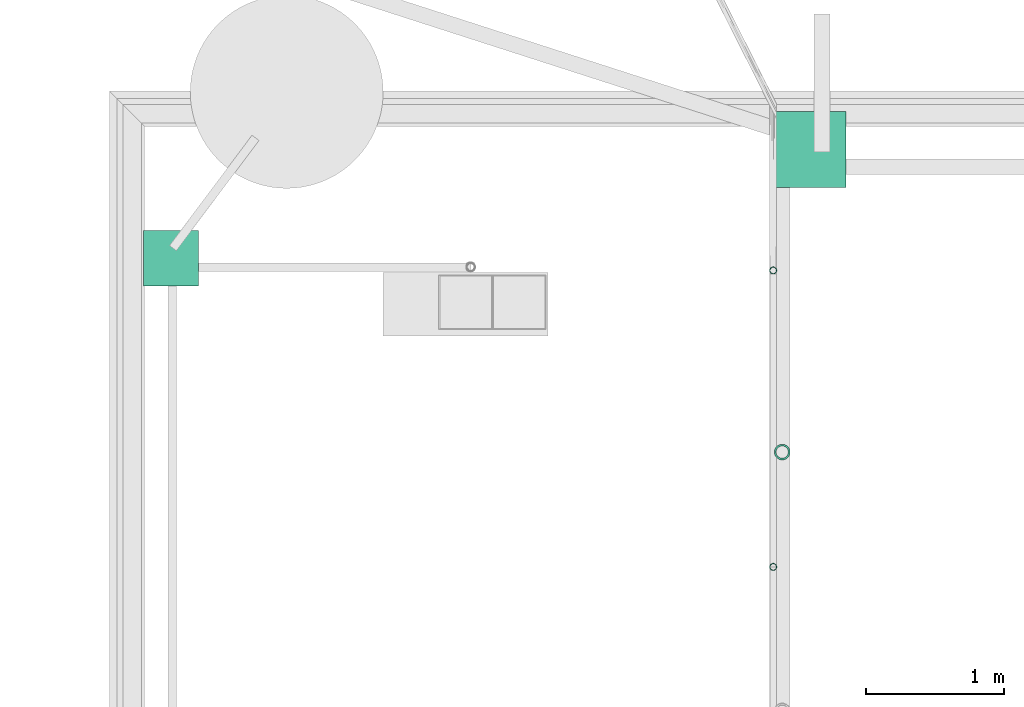
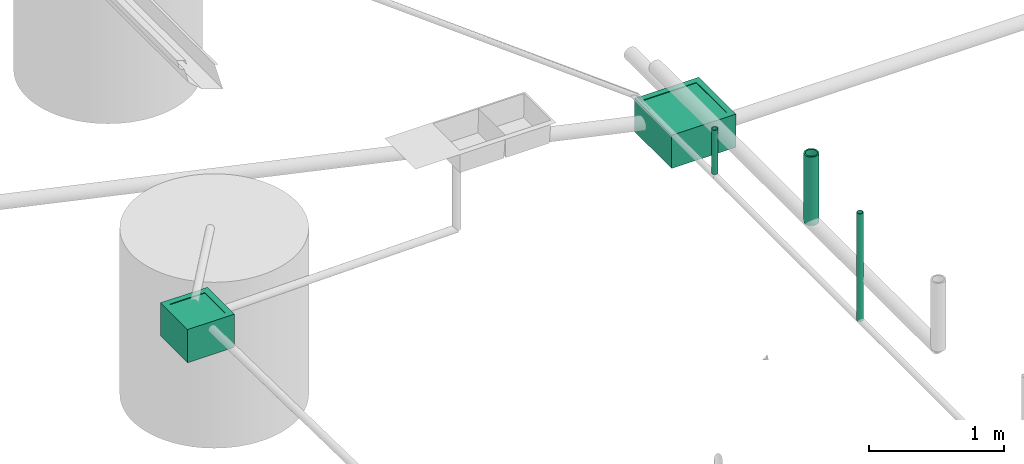
# One storey, part 11 of 15: 3 pipe segments, 2 distribution chamber elements.
"""IFC4X3_ADD2 building model written with IfcOpenShell, lengths in metres."""

import ifcopenshell
import ifcopenshell.guid

model = None  # the IFC model being written
_history = None  # IfcOwnerHistory: only IFC2X3 demands one
_inside = {}  # id of a spatial element -> (the spatial element, [elements in it])
_under = {}  # id of a project, library or spatial element -> (it, [spatial elements below it])
_declared = {}  # id of a project -> (the project, [libraries it declares])
_typed = {}  # id of a type object -> (the type object, [elements of that type])
_made_of = {}  # id of a material, layer set ... -> (it, [elements and type objects made of it])


def new_model(schema):
    """Start an empty IFC model of exactly this schema.

    Asked for "IFC4X3", IfcOpenShell would pick the latest addendum, in which some entities
    have other attributes; the version numbers below select the first issue.
    IFC2X3 requires an IfcOwnerHistory on every rooted entity: one is made here for all.
    """
    global model, _history
    if schema == "IFC4X3":
        model = ifcopenshell.file(schema_version=(4, 3, 0, 0))
    else:
        model = ifcopenshell.file(schema=schema)
    _inside.clear()
    _under.clear()
    _declared.clear()
    _typed.clear()
    _made_of.clear()
    _history = None
    if model.schema == "IFC2X3":
        org = make("IfcOrganization", Name="unknown")
        user = make(
            "IfcPersonAndOrganization",
            ThePerson=make("IfcPerson", FamilyName="unknown"),
            TheOrganization=org,
        )
        app = make(
            "IfcApplication",
            ApplicationDeveloper=org,
            Version="unknown",
            ApplicationFullName="unknown",
            ApplicationIdentifier="unknown",
        )
        _history = make(
            "IfcOwnerHistory",
            OwningUser=user,
            OwningApplication=app,
            ChangeAction="ADDED",
            CreationDate=0,
        )
    return model


def make(cls, **values):
    """One entity of the class cls with the attributes given. An attribute that is None is left unset."""
    return model.create_entity(
        cls, **{name: value for name, value in values.items() if value is not None}
    )


def entity(cls, *values):
    """Any entity or typed value of the class cls, its attributes in the order of the schema. None: left unset."""
    e = model.create_entity(cls)
    for i, value in enumerate(values):
        if value is not None:
            e[i] = value
    return e


def rooted(cls, **values):
    """An entity with a GlobalId (a new one), such as an element, a storey or a relation."""
    return make(cls, GlobalId=ifcopenshell.guid.new(), OwnerHistory=_history, **values)


def si_unit(unit_type, name, prefix=None):
    """IfcSIUnit, for example si_unit("LENGTHUNIT", "METRE", prefix="MILLI")."""
    return make("IfcSIUnit", UnitType=unit_type, Prefix=prefix, Name=name)


def converted_unit(unit_type, name, factor, base, dimensions=None, offset=None):
    """IfcConversionBasedUnit, such as the inch: factor (a typed value) times the base unit."""
    return make(
        "IfcConversionBasedUnit"
        if offset is None
        else "IfcConversionBasedUnitWithOffset",
        ConversionOffset=offset,
        Dimensions=None
        if dimensions is None
        else entity("IfcDimensionalExponents", *dimensions),
        UnitType=unit_type,
        Name=name,
        ConversionFactor=make(
            "IfcMeasureWithUnit", ValueComponent=factor, UnitComponent=base
        ),
    )


def assignment(units):
    """IfcUnitAssignment: the units of a project."""
    return None if units is None else make("IfcUnitAssignment", Units=units)


def point(xyz):
    """IfcCartesianPoint."""
    return None if xyz is None else make("IfcCartesianPoint", Coordinates=xyz)


def direction(xyz):
    """IfcDirection."""
    return None if xyz is None else make("IfcDirection", DirectionRatios=xyz)


def frame(location, z_axis=None, x_axis=None):
    """IfcAxis2Placement3D, a coordinate frame: its origin and axes. An axis left out is left unset."""
    return make(
        "IfcAxis2Placement3D",
        Location=point(location),
        Axis=direction(z_axis),
        RefDirection=direction(x_axis),
    )


def frame_2d(location, x_axis=None):
    """IfcAxis2Placement2D, a coordinate frame in the plane: its origin and x axis."""
    return make(
        "IfcAxis2Placement2D", Location=point(location), RefDirection=direction(x_axis)
    )


def origin_with_axes():
    """The frame at (0, 0, 0) with the z axis (0, 0, 1) and the x axis (1, 0, 0) written out."""
    return frame((0.0, 0.0, 0.0), z_axis=(0.0, 0.0, 1.0), x_axis=(1.0, 0.0, 0.0))


def origin_2d_with_axis():
    """The frame at (0, 0) in the plane with the x axis (1, 0) written out."""
    return frame_2d((0.0, 0.0), x_axis=(1.0, 0.0))


def place(relative_to, where):
    """IfcLocalPlacement: puts the frame where relative to a parent placement (None: the world)."""
    return make(
        "IfcLocalPlacement", PlacementRelTo=relative_to, RelativePlacement=where
    )


def context(
    kind, dimensions, precision=None, world=None, true_north=None, identifier=None
):
    """IfcGeometricRepresentationContext, for example the 3D "Model" context."""
    return make(
        "IfcGeometricRepresentationContext",
        ContextIdentifier=identifier,
        ContextType=kind,
        CoordinateSpaceDimension=dimensions,
        Precision=precision,
        WorldCoordinateSystem=world,
        TrueNorth=true_north,
    )


def subcontext(parent, identifier, kind, view, scale=None):
    """IfcGeometricRepresentationSubContext, for example "Body" below "Model"."""
    return make(
        "IfcGeometricRepresentationSubContext",
        ContextIdentifier=identifier,
        ContextType=kind,
        ParentContext=parent,
        TargetScale=scale,
        TargetView=view,
    )


def project(units=None, contexts=None):
    """IfcProject with its units and contexts."""
    return rooted(
        "IfcProject",
        Name="project",
        RepresentationContexts=contexts,
        UnitsInContext=assignment(units),
    )


def spatial(cls, under=None, at=None, **own):
    """A site, building, storey or space (cls), placed at a placement, below another one or the project."""
    s = rooted(cls, ObjectPlacement=at, **own)
    if under is not None:
        _under.setdefault(under.id(), (under, []))[1].append(s)
    return s


def point_list(points):
    """IfcCartesianPointList2D or 3D."""
    cls = (
        "IfcCartesianPointList2D" if len(points[0]) == 2 else "IfcCartesianPointList3D"
    )
    return make(cls, CoordList=points)


def profile(cls, at=None, kind="AREA", **sizes):
    """A parametric profile (cls). Its sizes go by their IFC names, for example OverallWidth=200.0."""
    return make(cls, ProfileType=kind, Position=at, **sizes)


def hollow_circle(**sizes):
    """IfcCircleHollowProfileDef."""
    return profile("IfcCircleHollowProfileDef", **sizes)


def extrude(swept, where, along, depth):
    """IfcExtrudedAreaSolid: the profile swept, set in the frame where, extruded along a direction by depth."""
    return make(
        "IfcExtrudedAreaSolid",
        SweptArea=swept,
        Position=where,
        ExtrudedDirection=direction(along),
        Depth=depth,
    )


def polygons(points, faces, closed=None, point_numbers=None):
    """IfcPolygonalFaceSet: a face is its outer loop, then its inner loops; points numbered from 1."""
    made = []
    for loops in faces:
        if len(loops) == 1:
            made.append(make("IfcIndexedPolygonalFace", CoordIndex=loops[0]))
        else:
            made.append(
                make(
                    "IfcIndexedPolygonalFaceWithVoids",
                    CoordIndex=loops[0],
                    InnerCoordIndices=loops[1:],
                )
            )
    return make(
        "IfcPolygonalFaceSet",
        Coordinates=point_list(points),
        Closed=closed,
        Faces=made,
        PnIndex=point_numbers,
    )


def shape(context_of_items, identifier, shape_type, items):
    """IfcShapeRepresentation: the items that make up one representation, for example the "Body"."""
    return make(
        "IfcShapeRepresentation",
        ContextOfItems=context_of_items,
        RepresentationIdentifier=identifier,
        RepresentationType=shape_type,
        Items=items,
    )


def source(mapping_origin, context_of_items, identifier, shape_type, items):
    """IfcRepresentationMap: a shape defined once, which mapped items show again and again."""
    return make(
        "IfcRepresentationMap",
        MappingOrigin=mapping_origin,
        MappedRepresentation=shape(context_of_items, identifier, shape_type, items),
    )


def transform(
    local_origin,
    x_axis=None,
    y_axis=None,
    z_axis=None,
    scale=None,
    scale2=None,
    scale3=None,
    uniform=True,
):
    """IfcCartesianTransformationOperator3D, or its non-uniform kind. x_axis, y_axis, z_axis: its Axis1, 2, 3."""
    if uniform:
        return make(
            "IfcCartesianTransformationOperator3D",
            Axis1=direction(x_axis),
            Axis2=direction(y_axis),
            LocalOrigin=point(local_origin),
            Scale=scale,
            Axis3=direction(z_axis),
        )
    return make(
        "IfcCartesianTransformationOperator3DnonUniform",
        Axis1=direction(x_axis),
        Axis2=direction(y_axis),
        LocalOrigin=point(local_origin),
        Scale=scale,
        Axis3=direction(z_axis),
        Scale2=scale2,
        Scale3=scale3,
    )


def mapped(mapping_source, mapping_target):
    """IfcMappedItem: shows the shape of a source again, moved by a transform."""
    return make(
        "IfcMappedItem", MappingSource=mapping_source, MappingTarget=mapping_target
    )


def material(Name=None, Category=None):
    """IfcMaterial."""
    return make("IfcMaterial", Name=Name, Category=Category)


def material_profile(
    of_material, cross_section, Name=None, Category=None, Priority=None
):
    """IfcMaterialProfile: a cross section and its material."""
    return make(
        "IfcMaterialProfile",
        Name=Name,
        Material=of_material,
        Profile=cross_section,
        Priority=Priority,
        Category=Category,
    )


def profile_set(profiles, Name=None, composite=None):
    """IfcMaterialProfileSet."""
    return make(
        "IfcMaterialProfileSet",
        Name=Name,
        MaterialProfiles=profiles,
        CompositeProfile=composite,
    )


def profile_usage(for_profile_set, cardinal=None, extent=None):
    """IfcMaterialProfileSetUsage: how a profile set lies along its element."""
    return make(
        "IfcMaterialProfileSetUsage",
        ForProfileSet=for_profile_set,
        CardinalPoint=cardinal,
        ReferenceExtent=extent,
    )


def made_of(thing, what):
    """Note that an element or type object is made of a material, layer set ...; save() writes the relation."""
    if what is not None:
        _made_of.setdefault(what.id(), (what, []))[1].append(thing)
    return thing


def type_object(cls, material=None, **own):
    """A type object (cls), such as IfcWallType, which elements share."""
    return made_of(rooted(cls, **own), material)


def type_shapes(of_type, sources):
    """Give a type object the sources (RepresentationMaps) that its elements show as mapped items."""
    of_type.RepresentationMaps = sources


def element(
    cls,
    number,
    at=None,
    inside=None,
    cuts=None,
    type_object=None,
    material=None,
    context=None,
    identifier="Body",
    shape_type=None,
    held_by="IfcProductDefinitionShape",
    body=None,
    shapes=None,
    **own,
):
    """One element of the class cls, such as IfcWall. Its Tag is "e" and its number.

    at: its placement. inside: the storey or other place that contains it. cuts: it is an
    opening in that element (IfcRelVoidsElement). A single representation is given by context,
    identifier, shape_type and body (its items); several are given by shapes. held_by: the class
    of the entity that holds the representations. save() writes the other relations.
    """
    e = rooted(cls, Tag="e%d" % number, ObjectPlacement=at, **own)
    if body is not None:
        shapes = [shape(context, identifier, shape_type, body)]
    if shapes is not None:
        e.Representation = make(held_by, Representations=shapes)
    if inside is not None:
        _inside.setdefault(inside.id(), (inside, []))[1].append(e)
    if cuts is not None:
        rooted(
            "IfcRelVoidsElement", RelatingBuildingElement=cuts, RelatedOpeningElement=e
        )
    if type_object is not None:
        _typed.setdefault(type_object.id(), (type_object, []))[1].append(e)
    return made_of(e, material)


def aggregate(whole, parts):
    """IfcRelAggregates: a whole, such as a stair, and the parts it consists of."""
    return rooted("IfcRelAggregates", RelatingObject=whole, RelatedObjects=parts)


def save(model, path):
    """Write the relations noted so far, then the file.

    IfcRelAggregates (storeys below a building ...), IfcRelContainedInSpatialStructure (elements
    in a storey), IfcRelDefinesByType, IfcRelAssociatesMaterial and IfcRelDeclares: one each for
    every whole, place, type object, material and project.
    """
    for whole, parts in _under.values():
        aggregate(whole, parts)
    for where, things in _inside.values():
        rooted(
            "IfcRelContainedInSpatialStructure",
            RelatedElements=things,
            RelatingStructure=where,
        )
    for kind, things in _typed.values():
        rooted("IfcRelDefinesByType", RelatedObjects=things, RelatingType=kind)
    for what, things in _made_of.values():
        rooted("IfcRelAssociatesMaterial", RelatedObjects=things, RelatingMaterial=what)
    for by, libraries in _declared.values():
        rooted("IfcRelDeclares", RelatingContext=by, RelatedDefinitions=libraries)
    model.write(path)


model = new_model("IFC4X3_ADD2")

# Units and contexts
model_context = context("Model", 3, precision=1e-05, world=origin_with_axes())
plan_context = context("Plan", 2, precision=1e-05, world=origin_2d_with_axis())
body_context = subcontext(model_context, "Body", "Model", "MODEL_VIEW")
ifc_project = project(units=[si_unit("VOLUMEUNIT", "CUBIC_METRE"), si_unit("LENGTHUNIT", "METRE"), converted_unit("PLANEANGLEUNIT", "degree", entity("IfcReal", 0.0174532925199433), si_unit("PLANEANGLEUNIT", "RADIAN"), dimensions=[0, 0, 0, 0, 0, 0, 0]), si_unit("AREAUNIT", "SQUARE_METRE")], contexts=[model_context, plan_context])

# Site, building, storey
site_placement = place(None, origin_with_axes())
site = spatial("IfcSite", under=ifc_project, at=site_placement)
building_placement = place(site_placement, origin_with_axes())
building = spatial("IfcBuilding", under=site, at=building_placement, Name="Building")
storey_placement = place(building_placement, origin_with_axes())
storey = spatial("IfcBuildingStorey", under=building, at=storey_placement, Name="Plumbing")

# Distribution chamber elements
distribution_chamber_element_type_1 = type_object("IfcDistributionChamberElementType", Name="1.5ft_WCS", PredefinedType="INSPECTIONCHAMBER")
shared_shape_1 = source(origin_with_axes(), body_context, "Body", "Tessellation", [
    polygons([(0.0499999895691872, 0.0499999895691872, -0.0049999775364995), (0.0499999895691872, 0.0499999895691872, 1.78813941431599e-08), (0.5, 0.0499999895691872, 1.78813941431599e-08), (0.0499999895691872, 0.5, -0.0049999775364995), (0.0499999895691872, 0.5, 1.78813941431599e-08), (0.5, 0.5, -0.0049999775364995), (0.5, 0.5, 1.78813941431599e-08), (0.5, 0.0499999895691872, -0.0049999775364995)], [[[1, 2, 3]], [[4, 5, 2]], [[6, 7, 5]], [[8, 3, 7]], [[8, 6, 4]], [[5, 7, 3]], [[3, 8, 1]], [[2, 1, 4]], [[5, 4, 6]], [[7, 6, 8]], [[4, 1, 8]], [[3, 2, 5]]]),
    polygons([(0.550000011920929, 0.550000011920929, -0.299999982118607), (0.0, 0.550000011920929, 8.94069707157996e-09), (0.0, 0.550000011920929, -0.299999982118607), (0.550000011920929, 0.0, -0.299999982118607), (0.550000011920929, 0.550000011920929, 8.94069707157996e-09), (0.0, 0.0, -0.299999982118607), (0.0, 0.0, 8.94069707157996e-09), (0.550000011920929, 0.0, 8.94069707157996e-09), (0.5, 0.0499999709427357, 8.94069707157996e-09), (0.0499999709427357, 0.0499999709427357, 8.94069707157996e-09), (0.0499999709427357, 0.0499999709427357, -0.00499998638406396), (0.0499999709427357, 0.5, -0.00499998638406396), (0.0499999709427357, 0.5, 8.94069707157996e-09), (0.5, 0.5, -0.00499998638406396), (0.5, 0.5, 8.94069707157996e-09), (0.5, 0.0499999709427357, -0.00499998638406396), (0.493575930595398, 0.0564240589737892, -0.00499998638406396), (0.0564240589737892, 0.0564240589737892, -0.00499998638406396), (0.0564240589737892, 0.493575930595398, -0.19999997317791), (0.0564240589737892, 0.493575930595398, -0.00499998638406396), (0.0564240589737892, 0.0564240589737892, -0.19999997317791), (0.493575930595398, 0.493575930595398, -0.19999997317791), (0.493575930595398, 0.0564240589737892, -0.19999997317791), (0.493575930595398, 0.493575930595398, -0.00499998638406396)], [[[2, 5, 1]], [[1, 3, 2]], [[6, 3, 1]], [[1, 4, 6]], [[4, 1, 5]], [[3, 6, 7]], [[8, 7, 6]], [[6, 4, 8]], [[8, 9, 10]], [[9, 8, 5]], [[5, 8, 4]], [[10, 7, 8]], [[10, 11, 12]], [[11, 10, 9]], [[12, 13, 10]], [[7, 10, 13]], [[13, 12, 14]], [[14, 15, 13]], [[2, 13, 15]], [[13, 2, 7]], [[15, 5, 2]], [[5, 15, 9]], [[15, 14, 16]], [[16, 9, 15]], [[9, 16, 11]], [[16, 17, 18]], [[17, 16, 14]], [[18, 11, 16]], [[18, 21, 19]], [[19, 20, 18]], [[11, 18, 20]], [[21, 18, 17]], [[22, 19, 21]], [[21, 23, 22]], [[17, 23, 21]], [[24, 22, 23]], [[23, 17, 24]], [[12, 20, 24]], [[24, 14, 12]], [[14, 24, 17]], [[22, 24, 20]], [[20, 19, 22]], [[20, 12, 11]], [[7, 2, 3]]]),
])
type_shapes(distribution_chamber_element_type_1, [shared_shape_1])
distribution_chamber_element_1_placement = place(storey_placement, frame((9.11935234069824, 26.7009468078613, 0.0299999993294477), z_axis=(0.0, 0.0, 1.0), x_axis=(1.0, 0.0, 0.0)))
element("IfcDistributionChamberElement", 1, at=distribution_chamber_element_1_placement, inside=storey, type_object=distribution_chamber_element_type_1, Name="DistributionChamberElement", context=body_context, shape_type="MappedRepresentation", body=[
    mapped(shared_shape_1, transform((0.0, 0.0, 0.0), x_axis=(1.0, 0.0, 0.0), y_axis=(0.0, 1.0, 0.0), z_axis=(0.0, 0.0, 1.0), scale=1.0)),
])
distribution_chamber_element_type_2 = type_object("IfcDistributionChamberElementType", Name="1ft_WKR", PredefinedType="INSPECTIONCHAMBER")
shared_shape_2 = source(origin_with_axes(), body_context, "Body", "Tessellation", [
    polygons([(0.0499999895691872, 0.0499999895691872, -0.0049999775364995), (0.0499999895691872, 0.349999994039536, 1.78813941431599e-08), (0.349999994039536, 0.0499999895691872, -0.0049999775364995), (0.0499999895691872, 0.0499999895691872, 1.78813941431599e-08), (0.349999994039536, 0.349999994039536, -0.0049999775364995), (0.349999994039536, 0.349999994039536, 1.78813941431599e-08), (0.0499999895691872, 0.349999994039536, -0.0049999775364995), (0.349999994039536, 0.0499999895691872, 1.78813941431599e-08)], [[[4, 8, 3, 1]], [[2, 4, 1, 7]], [[6, 2, 7, 5]], [[8, 6, 5, 3]], [[5, 7, 1, 3]], [[6, 8, 4, 2]]]),
    polygons([(0.400000005960464, 0.400000005960464, 8.94069707157996e-09), (0.400000005960464, 0.400000005960464, -0.299999982118607), (0.400000005960464, 0.0, 8.94069707157996e-09), (0.0, 0.400000005960464, 8.94069707157996e-09), (0.350000023841858, 0.350000023841858, 8.94069707157996e-09), (0.350000023841858, 0.0499999709427357, 8.94069707157996e-09), (0.0499999709427357, 0.350000023841858, 8.94069707157996e-09), (0.350000023841858, 0.350000023841858, -0.00499998638406396), (0.350000023841858, 0.0499999709427357, -0.00499998638406396), (0.0499999709427357, 0.350000023841858, -0.00499998638406396), (0.343575924634933, 0.343575924634933, -0.00499998638406396), (0.343575924634933, 0.0564240589737892, -0.00499998638406396), (0.0564240589737892, 0.343575924634933, -0.00499998638406396), (0.343575924634933, 0.343575924634933, -0.19999997317791), (0.343575924634933, 0.0564240589737892, -0.19999997317791), (0.0564240589737892, 0.343575924634933, -0.19999997317791), (0.0564240589737892, 0.0564240589737892, -0.19999997317791), (0.0564240589737892, 0.0564240589737892, -0.00499998638406396), (0.0499999709427357, 0.0499999709427357, -0.00499998638406396), (0.0499999709427357, 0.0499999709427357, 8.94069707157996e-09), (0.0, 0.0, 8.94069707157996e-09), (0.0, 0.0, -0.299999982118607), (0.0, 0.400000005960464, -0.299999982118607), (0.400000005960464, 0.0, -0.299999982118607)], [[[23, 4, 1, 2]], [[2, 1, 3, 24]], [[3, 1, 5, 6]], [[1, 4, 7, 5]], [[6, 5, 8, 9]], [[5, 7, 10, 8]], [[9, 8, 11, 12]], [[8, 10, 13, 11]], [[12, 11, 14, 15]], [[11, 13, 16, 14]], [[15, 14, 16, 17]], [[13, 18, 17, 16]], [[18, 12, 15, 17]], [[19, 9, 12, 18]], [[10, 19, 18, 13]], [[20, 6, 9, 19]], [[7, 20, 19, 10]], [[21, 3, 6, 20]], [[4, 21, 20, 7]], [[22, 21, 4, 23]], [[24, 3, 21, 22]], [[23, 2, 24, 22]]]),
])
type_shapes(distribution_chamber_element_type_2, [shared_shape_2])
distribution_chamber_element_2_placement = place(storey_placement, frame((4.56915855407715, 25.9874706268311, 0.299999982118607), z_axis=(0.0, 0.0, 1.0), x_axis=(1.0, 0.0, 0.0)))
element("IfcDistributionChamberElement", 2, at=distribution_chamber_element_2_placement, inside=storey, type_object=distribution_chamber_element_type_2, Name="DistributionChamberElement", context=body_context, shape_type="MappedRepresentation", body=[
    mapped(shared_shape_2, transform((0.0, 0.0, 0.0), x_axis=(1.0, 0.0, 0.0), y_axis=(0.0, 1.0, 0.0), z_axis=(0.0, 0.0, 1.0), scale=1.0)),
])

# Pipe segments
ifc_material_1 = material()
ifc_material_profile_1 = material_profile(ifc_material_1, hollow_circle(Radius=0.0571499988436699, WallThickness=0.012699999846518))
ifc_profile_set_1 = profile_set([ifc_material_profile_1])
ifc_profile_usage_1 = profile_usage(ifc_profile_set_1)
pipe_segment_type_1 = type_object("IfcPipeSegmentType", Name="4inch Tank", PredefinedType="FLEXIBLESEGMENT", material=ifc_profile_set_1)
pipe_segment_1_placement = place(storey_placement, frame((9.20528697967529, 24.781192779541, 0.387610822916031), z_axis=(8.74228192060391e-08, -1.19209282445353e-07, 0.999999999999989), x_axis=(-0.999999999999921, -3.89414367418763e-07, 8.74227694680416e-08)))
element("IfcPipeSegment", 3, at=pipe_segment_1_placement, inside=storey, type_object=pipe_segment_type_1, material=ifc_profile_usage_1, Name="PipeSegment", PredefinedType="FLEXIBLESEGMENT", context=body_context, shape_type="SweptSolid", body=[
    extrude(hollow_circle(Radius=0.0571499988436699, WallThickness=0.012699999846518), origin_with_axes(), (0.0, 0.0, 1.0), 0.619042638491849),
])
ifc_material_2 = material(Name="Wall")
ifc_material_profile_2 = material_profile(ifc_material_2, hollow_circle(Radius=0.0253999996930361, WallThickness=0.0020000000949949))
ifc_profile_set_2 = profile_set([ifc_material_profile_2])
ifc_profile_usage_2 = profile_usage(ifc_profile_set_2)
ifc_material_profile_3 = material_profile(ifc_material_2, hollow_circle(Radius=0.0253999996930361, WallThickness=0.0020000000949949))
ifc_profile_set_3 = profile_set([ifc_material_profile_3])
pipe_segment_type_2 = type_object("IfcPipeSegmentType", Name="2inch-bath outlet", PredefinedType="FLEXIBLESEGMENT", material=ifc_profile_set_3)
pipe_segment_2_placement = place(storey_placement, frame((9.13959503173828, 23.9477500915527, 0.0252149868756533), z_axis=(-8.74227481517655e-08, -1.19209317972489e-07, 0.999999999999989), x_axis=(-0.999999999999921, -3.89414367418763e-07, -8.7422797889751e-08)))
element("IfcPipeSegment", 4, at=pipe_segment_2_placement, inside=storey, type_object=pipe_segment_type_2, material=ifc_profile_usage_2, Name="PipeSegment", context=body_context, shape_type="SweptSolid", body=[
    extrude(hollow_circle(Radius=0.0253999996930361, WallThickness=0.0020000000949949), origin_with_axes(), (0.0, 0.0, 1.0), 0.974785034006024),
])
ifc_profile_usage_3 = profile_usage(ifc_profile_set_2)
pipe_segment_3_placement = place(storey_placement, frame((9.13959503173828, 26.0993576049805, 0.0504299513995647), z_axis=(-8.74227481517655e-08, -1.19209317972489e-07, 0.999999999999989), x_axis=(-0.999999999999921, -3.89414367418763e-07, -8.7422797889751e-08)))
element("IfcPipeSegment", 5, at=pipe_segment_3_placement, inside=storey, type_object=pipe_segment_type_2, material=ifc_profile_usage_3, Name="PipeSegment", context=body_context, shape_type="SweptSolid", body=[
    extrude(hollow_circle(Radius=0.0253999996930361, WallThickness=0.0020000000949949), origin_with_axes(), (0.0, 0.0, 1.0), 0.399570052224862),
])

save(model, "model.ifc")
